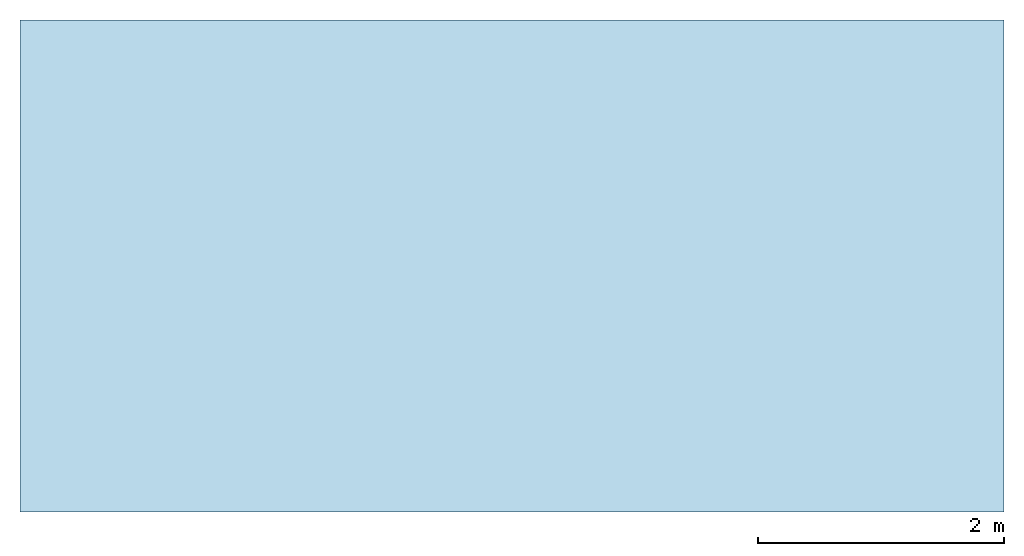
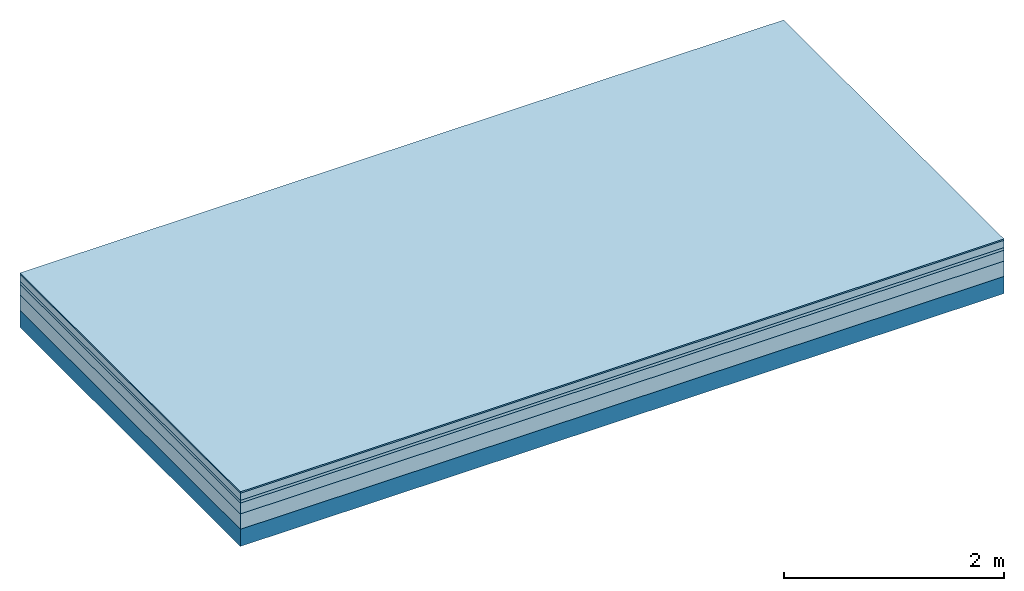
# One storey: 5 plates, 1 member, 1 element without a shape of its own.
"""IFC4 building model written with IfcOpenShell, lengths in metres."""

from ifc_helpers import new_model, si_unit, derived_unit, direction, frame, frame_2d, origin, origin_with_axes, place, context, project, spatial, rectangle, extrude, material, layer, layer_set, type_object, element, aggregate, save


model = new_model("IFC4")

# Units and contexts
plan_context = context("Plan", 3, precision=1e-05, world=origin(), true_north=direction((0.0, 1.0)))
model_context = context("Model", 3, precision=1e-05, world=origin(), true_north=direction((0.0, 1.0)))
ifc_project = project(units=[si_unit("LENGTHUNIT", "METRE"), derived_unit("SOUNDPRESSUREUNIT", [(si_unit("PRESSUREUNIT", "PASCAL", prefix="MICRO"), 0)]), si_unit("ENERGYUNIT", "JOULE", prefix="MEGA"), si_unit("MASSUNIT", "GRAM", prefix="KILO"), derived_unit("THERMALTRANSMITTANCEUNIT", [(si_unit("POWERUNIT", "WATT"), 1), (si_unit("AREAUNIT", "SQUARE_METRE"), -1), (si_unit("THERMODYNAMICTEMPERATUREUNIT", "KELVIN"), -1)]), derived_unit("AREADENSITYUNIT", [(si_unit("MASSUNIT", "GRAM", prefix="KILO"), 1), (si_unit("AREAUNIT", "SQUARE_METRE"), -1)]), derived_unit("USERDEFINED", [(si_unit("ENERGYUNIT", "JOULE", prefix="MEGA"), 1), (si_unit("AREAUNIT", "SQUARE_METRE"), -1)])], contexts=[plan_context, model_context])

# Site, building, storey
site = spatial("IfcSite", under=ifc_project)
building_placement = place(None, origin())
building = spatial("IfcBuilding", under=site, at=building_placement)
storey_placement = place(building_placement, origin())
storey = spatial("IfcBuildingStorey", under=building, at=storey_placement)

# Slab, member, plates
ifc_material_1 = material(Category="11.013")
ifc_layer_1 = layer(ifc_material_1, 0.015, Name="Flooring")
ifc_material_2 = material(Name="Cement screed", Category="04.006")
ifc_layer_2 = layer(ifc_material_2, 0.08, Name="On-material")
ifc_material_3 = material(Name="Wood fiber generic product", Category="10.009")
ifc_layer_3 = layer(ifc_material_3, 0.03, Name="Impact sound insulation")
ifc_material_4 = material(Name="Cement screed with EPS", Category="04.006")
ifc_layer_4 = layer(ifc_material_4, 0.12, Name="on Supporting structure")
ifc_material_5 = material(Category="01.002")
ifc_layer_5 = layer(ifc_material_5, 0.17, Name="Sub-floor")
ifc_material_6 = material(Name="Rigid, of the art")
ifc_layer_6 = layer(ifc_material_6, 0.0, Name="Bond")
ifc_layer_7 = layer(None, 0.19, Name="Supporting structure")
ifc_layer_set = layer_set([ifc_layer_1, ifc_layer_2, ifc_layer_3, ifc_layer_4, ifc_layer_5, ifc_layer_6, ifc_layer_7])
slab_type = type_object("IfcSlabType", Name="A2221", PredefinedType="NOTDEFINED", material=ifc_layer_set)
slab_placement = place(None, frame((0.0, 0.0, 0.0), z_axis=(0.0, 0.0, -1.0), x_axis=(1.0, 0.0, 0.0)))
slab = element("IfcSlab", 1, at=slab_placement, inside=storey, type_object=slab_type, material=ifc_layer_set, Name="Slab #1")
ifc_material_7 = material(Name="Solid timber panel")
member_placement = place(slab_placement, origin())
member = element("IfcMember", 2, at=member_placement, material=ifc_material_7, Name="Supporting structure", context=plan_context, shape_type="SweptSolid", body=[
    extrude(rectangle(XDim=1.0, YDim=0.19, at=frame_2d((0.5, 0.095), x_axis=(1.0, 0.0))), frame((0.0, 4.0, 0.415), z_axis=(0.0, -1.0, 0.0), x_axis=(1.0, 0.0, 0.0)), (0.0, 0.0, 1.0), 4.0),
    extrude(rectangle(XDim=1.0, YDim=0.19, at=frame_2d((0.5, 0.095), x_axis=(1.0, 0.0))), frame((1.0, 4.0, 0.415), z_axis=(0.0, -1.0, 0.0), x_axis=(1.0, 0.0, 0.0)), (0.0, 0.0, 1.0), 4.0),
    extrude(rectangle(XDim=1.0, YDim=0.19, at=frame_2d((0.5, 0.095), x_axis=(1.0, 0.0))), frame((2.0, 4.0, 0.415), z_axis=(0.0, -1.0, 0.0), x_axis=(1.0, 0.0, 0.0)), (0.0, 0.0, 1.0), 4.0),
    extrude(rectangle(XDim=1.0, YDim=0.19, at=frame_2d((0.5, 0.095), x_axis=(1.0, 0.0))), frame((3.0, 4.0, 0.415), z_axis=(0.0, -1.0, 0.0), x_axis=(1.0, 0.0, 0.0)), (0.0, 0.0, 1.0), 4.0),
    extrude(rectangle(XDim=1.0, YDim=0.19, at=frame_2d((0.5, 0.095), x_axis=(1.0, 0.0))), frame((4.0, 4.0, 0.415), z_axis=(0.0, -1.0, 0.0), x_axis=(1.0, 0.0, 0.0)), (0.0, 0.0, 1.0), 4.0),
    extrude(rectangle(XDim=1.0, YDim=0.19, at=frame_2d((0.5, 0.095), x_axis=(1.0, 0.0))), frame((5.0, 4.0, 0.415), z_axis=(0.0, -1.0, 0.0), x_axis=(1.0, 0.0, 0.0)), (0.0, 0.0, 1.0), 4.0),
    extrude(rectangle(XDim=1.0, YDim=0.19, at=frame_2d((0.5, 0.095), x_axis=(1.0, 0.0))), frame((6.0, 4.0, 0.415), z_axis=(0.0, -1.0, 0.0), x_axis=(1.0, 0.0, 0.0)), (0.0, 0.0, 1.0), 4.0),
    extrude(rectangle(XDim=1.0, YDim=0.19, at=frame_2d((0.5, 0.095), x_axis=(1.0, 0.0))), frame((7.0, 4.0, 0.415), z_axis=(0.0, -1.0, 0.0), x_axis=(1.0, 0.0, 0.0)), (0.0, 0.0, 1.0), 4.0),
])
plate_1_placement = place(slab_placement, origin())
plate_1 = element("IfcPlate", 3, at=plate_1_placement, material=ifc_material_1, Name="Flooring", context=plan_context, shape_type="SweptSolid", body=[
    extrude(rectangle(XDim=8.0, YDim=4.0, at=frame_2d((4.0, 2.0), x_axis=(1.0, 0.0))), origin_with_axes(), (0.0, 0.0, 1.0), 0.015),
])
plate_2_placement = place(slab_placement, origin())
plate_2 = element("IfcPlate", 4, at=plate_2_placement, material=ifc_material_2, Name="On-material", context=plan_context, shape_type="SweptSolid", body=[
    extrude(rectangle(XDim=8.0, YDim=4.0, at=frame_2d((4.0, 2.0), x_axis=(1.0, 0.0))), frame((0.0, 0.0, 0.015), z_axis=(0.0, 0.0, 1.0), x_axis=(1.0, 0.0, 0.0)), (0.0, 0.0, 1.0), 0.08),
])
plate_3_placement = place(slab_placement, origin())
plate_3 = element("IfcPlate", 5, at=plate_3_placement, material=ifc_material_3, Name="Impact sound insulation", context=plan_context, shape_type="SweptSolid", body=[
    extrude(rectangle(XDim=8.0, YDim=4.0, at=frame_2d((4.0, 2.0), x_axis=(1.0, 0.0))), frame((0.0, 0.0, 0.095), z_axis=(0.0, 0.0, 1.0), x_axis=(1.0, 0.0, 0.0)), (0.0, 0.0, 1.0), 0.03),
])
plate_4_placement = place(slab_placement, origin())
plate_4 = element("IfcPlate", 6, at=plate_4_placement, material=ifc_material_4, Name="on Supporting structure", context=plan_context, shape_type="SweptSolid", body=[
    extrude(rectangle(XDim=8.0, YDim=4.0, at=frame_2d((4.0, 2.0), x_axis=(1.0, 0.0))), frame((0.0, 0.0, 0.125), z_axis=(0.0, 0.0, 1.0), x_axis=(1.0, 0.0, 0.0)), (0.0, 0.0, 1.0), 0.12),
])
plate_5_placement = place(slab_placement, origin())
plate_5 = element("IfcPlate", 7, at=plate_5_placement, material=ifc_material_5, Name="Sub-floor", context=plan_context, shape_type="SweptSolid", body=[
    extrude(rectangle(XDim=8.0, YDim=4.0, at=frame_2d((4.0, 2.0), x_axis=(1.0, 0.0))), frame((0.0, 0.0, 0.245), z_axis=(0.0, 0.0, 1.0), x_axis=(1.0, 0.0, 0.0)), (0.0, 0.0, 1.0), 0.17),
])
aggregate(slab, [plate_1, plate_2, plate_3, plate_4, plate_5, member])

save(model, "model.ifc")
